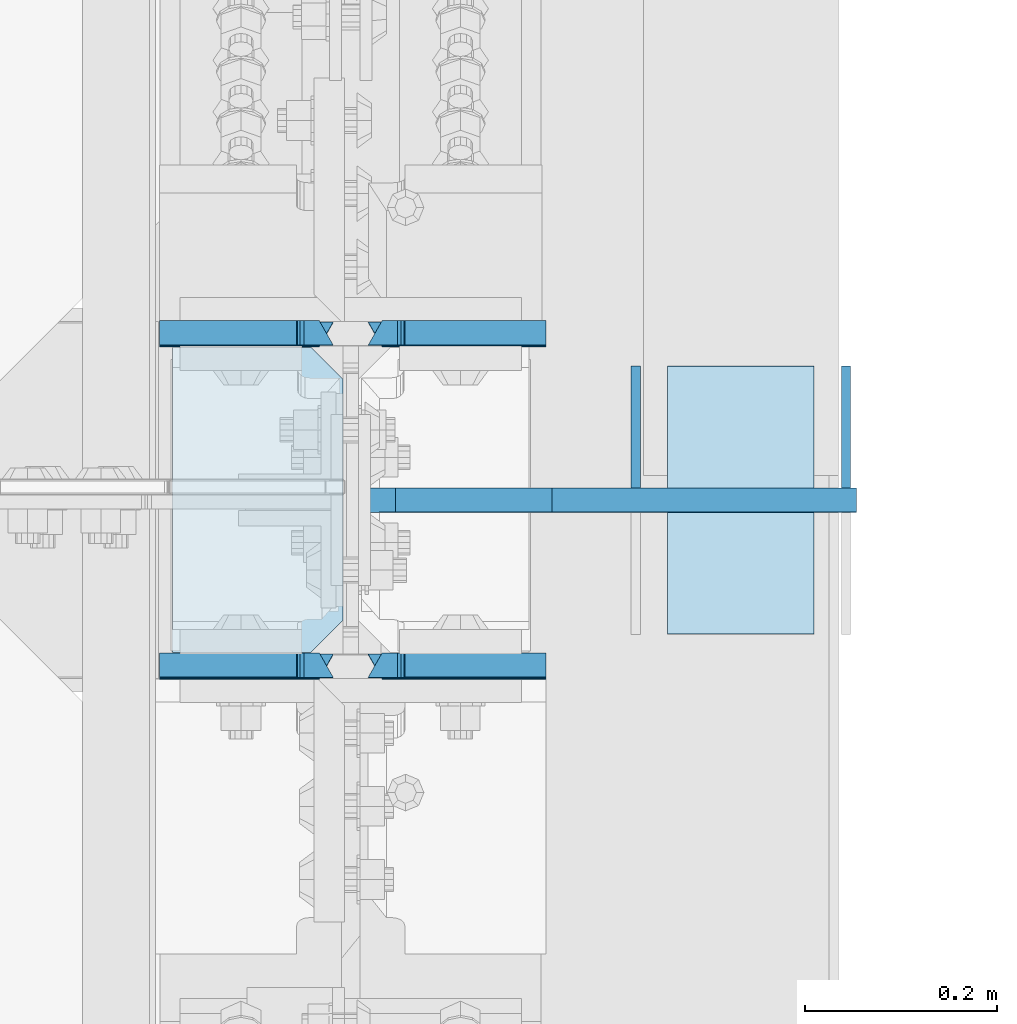
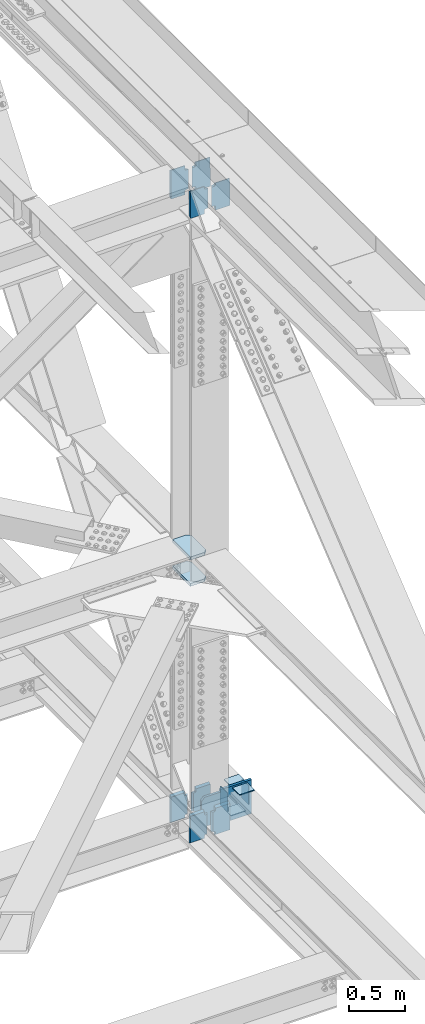
# One storey, part 3625 of 3843: 16 plates, 8 elements without a shape of their own.
"""IFC2X3 building model written with IfcOpenShell, lengths in millimetres."""

from ifc_helpers import new_model, si_unit, frame, origin_with_axes, place, context, subcontext, project, spatial, faceted_brep, material, type_object, element, aggregate, save


model = new_model("IFC2X3")

# Units and contexts
model_context = context("Model", 3, precision=1e-05, world=origin_with_axes())
body_context = subcontext(model_context, "Body", "Model", "MODEL_VIEW")
ifc_project = project(units=[si_unit("LENGTHUNIT", "METRE", prefix="MILLI"), si_unit("AREAUNIT", "SQUARE_METRE"), si_unit("VOLUMEUNIT", "CUBIC_METRE"), si_unit("MASSUNIT", "GRAM", prefix="KILO"), si_unit("TIMEUNIT", "SECOND"), si_unit("PLANEANGLEUNIT", "RADIAN"), si_unit("SOLIDANGLEUNIT", "STERADIAN"), si_unit("THERMODYNAMICTEMPERATUREUNIT", "DEGREE_CELSIUS"), si_unit("LUMINOUSINTENSITYUNIT", "LUMEN")], contexts=[model_context])

# Site, building, storey
site_placement = place(None, origin_with_axes())
site = spatial("IfcSite", under=ifc_project, at=site_placement, CompositionType="ELEMENT")
building_placement = place(site_placement, origin_with_axes())
building = spatial("IfcBuilding", under=site, at=building_placement, Name="Undefined", CompositionType="ELEMENT")
storey_placement = place(building_placement, origin_with_axes())
storey = spatial("IfcBuildingStorey", under=building, at=storey_placement, Name="Undefined", CompositionType="ELEMENT", Elevation=0.0)

# Assembly, plates
assembly_1_placement = place(storey_placement, origin_with_axes())
assembly_1 = element("IfcElementAssembly", 1, at=assembly_1_placement, inside=storey, Name="BEAM", AssemblyPlace="NOTDEFINED", PredefinedType="RIGID_FRAME")
ifc_material = material(Name="STEEL/A572-50")
plate_type_1 = type_object("IfcPlateType", PredefinedType="NOTDEFINED")
plate_1_placement = place(assembly_1_placement, frame((85852.0, 83810.7882898343, 39343.574608476), z_axis=(0.0, 0.00349392500078829, 0.999993896225416), x_axis=(-1.0, 0.0, 0.0)))
plate_1 = element("IfcPlate", 2, at=plate_1_placement, type_object=plate_type_1, material=ifc_material, Name="PLATE", context=body_context, shape_type="Brep", body=[
    faceted_brep([(0.0, 12.6999999991967, 299.81679228392), (0.0, -12.7000000008993, 314.308156892032), (146.843749999985, -12.7000000008993, 314.308156892032), (146.843749999985, 12.6999999991967, 299.81679228392), (0.0, 12.6999999999825, 14.4916120159614), (0.0, -12.6999999999971, 0.0), (146.843749999985, 12.6999999999825, 14.4916120159614), (146.843749999985, -12.7000000000844, 2.18278728425503e-11), (146.843749999985, 12.6999999999098, 38.1890602041385), (146.843749999985, -12.7000000001572, 38.1003132816259), (147.810479922569, 12.6999999998952, 43.0491693876829), (147.810479922569, -12.7000000001644, 42.9604224651703), (150.563493823051, 12.6999999998734, 47.169371005024), (150.563493823051, -12.7000000001863, 47.0806240825113), (154.683670291211, 12.6999999998734, 49.9224017096567), (154.683670291211, -12.7000000001935, 49.833654787144), (159.543749809251, 12.6999999998661, 50.8891375330786), (159.543749809251, -12.7000000001935, 50.800390610566), (170.452258242993, 12.700000000099, 50.8891375249077), (184.943749999991, -12.7000000000116, 50.8003906183731), (159.543749809251, -12.7000000008484, 263.417469232591), (154.683670291211, -12.7000000008557, 264.384205056005), (150.563493823051, -12.7000000008629, 267.137235760645), (147.810479922569, -12.7000000008702, 271.257437377986), (146.843749999985, -12.7000000008848, 276.117546561523), (184.943749999991, -12.6999999997643, 263.417469235843), (146.843749999985, 12.6999999991749, 276.206293484036), (147.810479922569, 12.6999999991895, 271.346184300499), (150.563493823051, 12.699999999204, 267.225982683158), (154.683670291211, 12.6999999992113, 264.472951978518), (159.543749809251, 12.6999999992186, 263.506216155103), (170.452258242993, 12.7000000003609, 263.506216142385)], [[[0, 1, 2, 3]], [[4, 5, 1, 0]], [[5, 4, 6, 7]], [[7, 6, 8, 9]], [[9, 8, 10, 11]], [[11, 10, 12, 13]], [[13, 12, 14, 15]], [[15, 14, 16, 17]], [[17, 16, 18, 19]], [[20, 21, 22, 23, 24, 2, 1, 5, 7, 9, 11, 13, 15, 17, 19, 25]], [[2, 24, 26, 3]], [[23, 27, 26, 24]], [[22, 28, 27, 23]], [[21, 29, 28, 22]], [[20, 30, 29, 21]], [[16, 14, 12, 10, 8, 6, 4, 0, 3, 26, 27, 28, 29, 30, 31, 18]], [[25, 19, 18, 31]], [[30, 20, 25, 31]]]),
])
plate_2_placement = place(assembly_1_placement, frame((85852.0, 84156.860333929, 39342.1240186234), z_axis=(0.0, 0.00349392500078829, 0.999993896225416), x_axis=(-1.0, 0.0, 0.0)))
plate_2 = element("IfcPlate", 3, at=plate_2_placement, type_object=plate_type_1, material=ifc_material, Name="PLATE", context=body_context, shape_type="Brep", body=[
    faceted_brep([(0.0, 12.6999999991967, 299.815314113897), (0.0, -12.7000000009139, 314.306688066332), (146.843749999985, -12.7000000009139, 314.306688066332), (146.843749999985, 12.6999999991967, 299.815314113897), (0.0, 12.699999999968, 25.3758197481584), (0.0, -12.7000000000844, 10.8843271002261), (146.843749999956, 12.699999999968, 25.3758197481584), (146.843749999956, -12.7000000000844, 10.8843271002261), (146.843749999956, 12.6999999998807, 49.0733067682668), (146.843749999956, -12.6999999951659, 48.9845598546235), (147.81047992254, 12.6999999998807, 53.9334159518039), (147.81047992254, -12.699999995617, 53.8446690381534), (150.563493823021, 12.6999999998661, 58.053617569145), (150.563493823021, -12.6999999967666, 57.9648706554945), (154.683670291182, 12.6999999998516, 60.8066482737631), (154.683670291182, -12.6999999983964, 60.7179013601199), (159.543749809221, 12.6999999998516, 61.773384097185), (159.543749809221, -12.7000000002881, 61.68463718352), (170.452258243124, 12.6999999998516, 61.773384097185), (184.943749999962, -12.7000000242551, 61.6846371834399), (159.543749809251, -12.7000000008484, 263.417469232591), (154.683670291211, -12.7000000008557, 264.384205056005), (150.563493823051, -12.7000000008629, 267.137235760645), (147.810479922569, -12.7000000008702, 271.257437377986), (146.843749999985, -12.7000000008848, 276.117546561523), (184.943749999991, -12.6999999997643, 263.417469235843), (146.843749999985, 12.6999999991749, 276.206293484036), (147.810479922569, 12.6999999991895, 271.346184300499), (150.563493823051, 12.699999999204, 267.225982683158), (154.683670291211, 12.6999999992113, 264.472951978518), (159.543749809251, 12.6999999992186, 263.506216155103), (170.452258242993, 12.7000000003609, 263.506216142385)], [[[0, 1, 2, 3]], [[4, 5, 1, 0]], [[5, 4, 6, 7]], [[7, 6, 8, 9]], [[9, 8, 10, 11]], [[11, 10, 12, 13]], [[13, 12, 14, 15]], [[15, 14, 16, 17]], [[17, 16, 18, 19]], [[20, 21, 22, 23, 24, 2, 1, 5, 7, 9, 11, 13, 15, 17, 19, 25]], [[2, 24, 26, 3]], [[23, 27, 26, 24]], [[22, 28, 27, 23]], [[21, 29, 28, 22]], [[20, 30, 29, 21]], [[16, 14, 12, 10, 8, 6, 4, 0, 3, 26, 27, 28, 29, 30, 31, 18]], [[25, 19, 18, 31]], [[30, 20, 25, 31]]]),
])

assembly_2_placement = place(storey_placement, origin_with_axes())
assembly_2 = element("IfcElementAssembly", 4, at=assembly_2_placement, inside=storey, Name="BEAM", AssemblyPlace="NOTDEFINED", PredefinedType="RIGID_FRAME")
plate_3_placement = place(assembly_2_placement, frame((85852.0, 83812.2315556504, 46115.8986620126), z_axis=(0.0, 0.00329764299921226, 0.999994562760543), x_axis=(-1.0, 0.0, 0.0)))
plate_3 = element("IfcPlate", 5, at=plate_3_placement, type_object=plate_type_1, material=ifc_material, Name="PLATE", context=body_context, shape_type="Brep", body=[
    faceted_brep([(146.843749999985, -12.7000000000771, 14.4914917543283), (0.0, -12.7000000000771, 14.4914917543283), (0.0, 12.6999999999971, 0.0), (146.843749999985, 12.7000000000262, 4.36557456851006e-11), (0.0, 12.7000000016269, 295.281578539543), (0.0, -12.6999999985273, 281.020609228879), (146.843749999985, -12.6999999985419, 280.976986643007), (146.843749999985, 12.7000000016269, 295.281578539543), (146.843749999985, -12.7000000008848, 276.117546561523), (146.843749999985, 12.6999999991749, 276.206293484036), (147.810479922569, -12.7000000008702, 271.257437377986), (147.810479922569, 12.6999999991895, 271.346184300499), (150.563493823051, -12.7000000008629, 267.137235760645), (150.563493823051, 12.699999999204, 267.225982683158), (154.683670291211, -12.7000000008557, 264.384205056005), (154.683670291211, 12.6999999992113, 264.472951978518), (159.543749809251, -12.7000000008484, 263.417469232591), (159.543749809251, 12.6999999992186, 263.506216155103), (170.452258242891, -12.699999999837, 263.417469255888), (184.943749999991, 12.7000000002081, 263.506216153903), (170.452258242891, -12.7000000000407, 50.7115631795969), (184.943749999991, 12.7000000001426, 50.8003101030481), (159.543749809265, -12.7000000000407, 50.7115631795969), (159.543749809265, 12.7000000001426, 50.8003101030481), (154.683670291226, -12.7000000000407, 49.7448273561822), (154.683670291226, 12.7000000001281, 49.8335742796335), (150.563493823065, -12.7000000000553, 46.9917966515568), (150.563493823065, 12.7000000001281, 47.0805435750153), (147.810479922584, -12.7000000000553, 42.8715950342303), (147.810479922584, 12.7000000001281, 42.9603419576888), (146.84375, -12.7000000000553, 38.0114858507077), (146.84375, 12.7000000001281, 38.1002327741662)], [[[0, 1, 2, 3]], [[4, 5, 6, 7]], [[7, 6, 8, 9]], [[10, 11, 9, 8]], [[12, 13, 11, 10]], [[14, 15, 13, 12]], [[16, 17, 15, 14]], [[17, 16, 18, 19]], [[19, 18, 20, 21]], [[22, 23, 21, 20]], [[24, 25, 23, 22]], [[26, 27, 25, 24]], [[28, 29, 27, 26]], [[30, 31, 29, 28]], [[31, 30, 0, 3]], [[4, 7, 9, 11, 13, 15, 17, 19, 21, 23, 25, 27, 29, 31, 3, 2]], [[5, 4, 2, 1]], [[30, 28, 26, 24, 22, 20, 18, 16, 14, 12, 10, 8, 6, 5, 1, 0]]]),
])
plate_4_placement = place(assembly_2_placement, frame((85852.0, 84158.303541667, 46114.4140680814), z_axis=(0.0, 0.00329764299921226, 0.999994562760543), x_axis=(-1.0, 0.0, 0.0)))
plate_4 = element("IfcPlate", 6, at=plate_4_placement, type_object=plate_type_1, material=ifc_material, Name="PLATE", context=body_context, shape_type="Brep", body=[
    faceted_brep([(146.843749999985, 12.7000000017142, 314.301781176837), (0.0, 12.7000000017142, 314.301781176837), (0.0, -12.6999999984546, 299.810289416484), (146.843749999985, -12.6999999984546, 299.810289416484), (146.843749999985, -12.7000000000771, 14.4914917543283), (0.0, -12.7000000000771, 14.4914917543283), (0.0, 12.6999999999971, 0.0), (146.843749999985, 12.7000000000262, 4.36557456851006e-11), (146.843749999985, 12.6999999999098, 38.1890602041385), (146.843749999985, -12.7000000001572, 38.1003132816259), (147.810479922569, 12.6999999998952, 43.0491693876829), (147.810479922569, -12.7000000001644, 42.9604224651703), (150.563493823051, 12.6999999998734, 47.169371005024), (150.563493823051, -12.7000000001863, 47.0806240825113), (154.683670291211, 12.6999999998734, 49.9224017096567), (154.683670291211, -12.7000000001935, 49.833654787144), (159.543749809251, 12.6999999998661, 50.8891375330786), (159.543749809251, -12.7000000001935, 50.800390610566), (184.943749999991, 12.7000000001572, 50.8891375333405), (170.452258242833, -12.7000000000262, 50.800390609882), (184.943749999991, 12.7000000002081, 263.506216153903), (170.452258242891, -12.699999999837, 263.417469255888), (159.543749809251, 12.6999999992186, 263.506216155103), (159.543749809251, -12.7000000008484, 263.417469232591), (154.683670291211, 12.6999999992113, 264.472951978518), (154.683670291211, -12.7000000008557, 264.384205056005), (150.563493823051, 12.699999999204, 267.225982683158), (150.563493823051, -12.7000000008629, 267.137235760645), (147.810479922569, 12.6999999991895, 271.346184300499), (147.810479922569, -12.7000000008702, 271.257437377986), (146.843749999985, 12.6999999991749, 276.206293484036), (146.843749999985, -12.7000000008848, 276.117546561523)], [[[0, 1, 2, 3]], [[4, 5, 6, 7]], [[8, 9, 4, 7]], [[9, 8, 10, 11]], [[11, 10, 12, 13]], [[13, 12, 14, 15]], [[15, 14, 16, 17]], [[17, 16, 18, 19]], [[20, 21, 19, 18]], [[22, 23, 21, 20]], [[23, 22, 24, 25]], [[25, 24, 26, 27]], [[27, 26, 28, 29]], [[29, 28, 30, 31]], [[31, 30, 0, 3]], [[5, 4, 9, 11, 13, 15, 17, 19, 21, 23, 25, 27, 29, 31, 3, 2]], [[6, 5, 2, 1]], [[30, 28, 26, 24, 22, 20, 18, 16, 14, 12, 10, 8, 7, 6, 1, 0]]]),
])

# Plate
plate_type_2 = type_object("IfcPlateType", PredefinedType="NOTDEFINED")
plate_5_placement = place(assembly_1_placement, frame((85630.54375, 83810.7882898345, 39343.574608476), z_axis=(0.0, 0.00349392500078829, 0.999993896225416), x_axis=(-1.0, 0.0, 0.0)))
plate_5 = element("IfcPlate", 7, at=plate_5_placement, type_object=plate_type_2, material=ifc_material, Name="PLATE", context=body_context, shape_type="Brep", body=[
    faceted_brep([(38.1000000000058, -12.6996899253718, 314.217780397244), (38.1000000000058, 12.6999999991967, 299.816792283993), (38.1000000000058, 12.6999999991749, 276.206293484051), (38.1000000000058, -12.7000000008848, 276.117546561538), (180.974999999991, -12.7000000008993, 314.308156892032), (180.974999999991, 12.6999999991967, 299.816792283993), (180.974999999991, -12.7000000000844, 2.18278728425503e-11), (180.974999999991, 12.6999999999825, 14.4916120159032), (38.1000000000058, -12.7000000000844, 2.18278728425503e-11), (38.1000000000058, 12.6999999999825, 14.4916120159032), (38.1000000000058, -12.7000000001572, 38.1003132816404), (38.1000000000058, 12.6999999999098, 38.1890602041531), (37.1332700774219, -12.7000000001644, 42.9604224651848), (37.1332700774219, 12.6999999998952, 43.0491693876975), (34.3802561769407, -12.7000000001863, 47.0806240825259), (34.3802561769407, 12.6999999998734, 47.1693710050386), (30.2600797087798, -12.7000000001935, 49.8336547871586), (30.2600797087798, 12.6999999998734, 49.9224017096712), (25.4000001907407, -12.7000000001935, 50.8003906105805), (25.4000001907407, 12.6999999998661, 50.8891375330932), (0.0, -12.7000000000262, 50.8003906045633), (14.4914917569986, 12.7000000001135, 50.8891375364256), (25.4000001907407, 12.6999999992186, 263.506216155118), (30.2600797087798, 12.6999999992113, 264.472951978532), (34.3802561769407, 12.699999999204, 267.225982683172), (37.1332700774219, 12.6999999991895, 271.346184300513), (14.4914917569986, 12.7000000003463, 263.506216154878), (37.1332700774219, -12.7000000008702, 271.257437378001), (34.3802561769407, -12.7000000008629, 267.13723576066), (30.2600797087798, -12.7000000008557, 264.38420505602), (25.4000001907407, -12.7000000008484, 263.417469232605), (0.0, -12.6999999997643, 263.417469223023)], [[[0, 1, 2, 3]], [[4, 5, 1, 0]], [[6, 7, 5, 4]], [[7, 6, 8, 9]], [[10, 11, 9, 8]], [[12, 13, 11, 10]], [[14, 15, 13, 12]], [[16, 17, 15, 14]], [[18, 19, 17, 16]], [[19, 18, 20, 21]], [[22, 23, 24, 25, 2, 1, 5, 7, 9, 11, 13, 15, 17, 19, 21, 26]], [[3, 2, 25, 27]], [[18, 16, 14, 12, 10, 8, 6, 4, 0, 3, 27, 28, 29, 30, 31, 20]], [[26, 21, 20, 31]], [[30, 22, 26, 31]], [[29, 23, 22, 30]], [[28, 24, 23, 29]], [[27, 25, 24, 28]]]),
])

plate_6_placement = place(assembly_1_placement, frame((85630.54375, 84156.860333929, 39342.1240186234), z_axis=(0.0, 0.00349392500078829, 0.999993896225416), x_axis=(-1.0, 0.0, 0.0)))
plate_6 = element("IfcPlate", 8, at=plate_6_placement, type_object=plate_type_2, material=ifc_material, Name="PLATE", context=body_context, shape_type="Brep", body=[
    faceted_brep([(38.1000000000058, -12.6996899253718, 314.217780397244), (38.1000000000058, 12.6999999991967, 299.81531411389), (38.1000000000058, 12.6999999991749, 276.206293484051), (38.1000000000058, -12.7000000008848, 276.117546561538), (180.974999999991, -12.7000000009139, 314.306688066332), (180.974999999991, 12.6999999991967, 299.81531411389), (180.974999999991, -12.7000000000844, 10.8843271002406), (180.974999999991, 12.699999999968, 25.3758197481657), (38.1000000000349, -12.7000000000844, 10.8843271002406), (38.1000000000349, 12.699999999968, 25.3758197481657), (38.1000000000349, -12.7000369811867, 48.9845597254389), (38.1000000000349, 12.6999999998807, 49.0733067683104), (37.133270077451, -12.7000348279835, 53.8446689164921), (37.133270077451, 12.6999999998807, 53.9334159518476), (34.3802561769699, -12.7000327852002, 57.9648705409709), (34.3802561769699, 12.6999999998661, 58.0536175691886), (30.2600797088089, -12.7000311637967, 60.7179012512643), (30.2600797088089, 12.6999999998516, 60.8066482738141), (25.4000001907698, -12.7000302106608, 61.6846370780186), (25.4000001907698, 12.6999999998516, 61.7733840972287), (0.0, -12.7000000002154, 61.6846371835709), (14.4914917568676, 12.6999999998516, 61.7733840972287), (25.4000001907407, 12.6999999992186, 263.506216155118), (30.2600797087798, 12.6999999992113, 264.472951978532), (34.3802561769407, 12.699999999204, 267.225982683172), (37.1332700774219, 12.6999999991895, 271.346184300513), (14.4914917569986, 12.7000000003463, 263.506216154878), (37.1332700774219, -12.7000000008702, 271.257437378001), (34.3802561769407, -12.7000000008629, 267.13723576066), (30.2600797087798, -12.7000000008557, 264.38420505602), (25.4000001907407, -12.7000000008484, 263.417469232605), (0.0, -12.6999999997643, 263.417469223023)], [[[0, 1, 2, 3]], [[4, 5, 1, 0]], [[6, 7, 5, 4]], [[7, 6, 8, 9]], [[10, 11, 9, 8]], [[12, 13, 11, 10]], [[14, 15, 13, 12]], [[16, 17, 15, 14]], [[18, 19, 17, 16]], [[19, 18, 20, 21]], [[22, 23, 24, 25, 2, 1, 5, 7, 9, 11, 13, 15, 17, 19, 21, 26]], [[3, 2, 25, 27]], [[18, 16, 14, 12, 10, 8, 6, 4, 0, 3, 27, 28, 29, 30, 31, 20]], [[26, 21, 20, 31]], [[30, 22, 26, 31]], [[29, 23, 22, 30]], [[28, 24, 23, 29]], [[27, 25, 24, 28]]]),
])

plate_7_placement = place(assembly_2_placement, frame((85630.54375, 83812.2315556503, 46115.8986620126), z_axis=(0.0, 0.00329764299921226, 0.999994562760543), x_axis=(-1.0, 0.0, 0.0)))
plate_7 = element("IfcPlate", 9, at=plate_7_placement, type_object=plate_type_2, material=ifc_material, Name="PLATE", context=body_context, shape_type="Brep", body=[
    faceted_brep([(180.974999999991, -12.7000000000844, 14.4914917571878), (38.1000000000058, -12.7000000000771, 14.4914917543283), (38.1000000000058, 12.7000000000262, 4.36557456851006e-11), (180.974999999991, 12.7000000000844, -7.27595761418343e-12), (37.1332700774074, -12.7000000000553, 42.8715950345577), (37.1332700774074, 12.7000000001281, 42.9603419580089), (38.0999999999913, 12.7000000001281, 38.1002327744864), (38.0999999999913, -12.7000000000553, 38.0114858510351), (34.3802561769262, -12.7000000000553, 46.9917966518769), (34.3802561769262, 12.7000000001281, 47.0805435753355), (30.2600797087653, -12.7000000000407, 49.7448273565024), (30.2600797087653, 12.7000000001281, 49.8335742799536), (25.4000001907261, -12.7000000000407, 50.711563179917), (25.4000001907261, 12.7000000001426, 50.8003101033755), (14.4914917571004, -12.7000000000407, 50.711563179917), (0.0, 12.7000000001426, 50.8003101033755), (14.4914917568531, -12.7000000008484, 263.417469232605), (0.0, 12.6999999992186, 263.506216155118), (25.4000001907407, -12.7000000008484, 263.417469232605), (25.4000001907407, 12.6999999992186, 263.506216155118), (30.2600797087798, -12.7000000008557, 264.38420505602), (30.2600797087798, 12.6999999992113, 264.472951978532), (34.3802561769407, -12.7000000008629, 267.13723576066), (34.3802561769407, 12.699999999204, 267.225982683172), (37.1332700774219, -12.7000000008702, 271.257437378001), (37.1332700774219, 12.6999999991895, 271.346184300513), (38.1000000000058, -12.7000000008848, 276.117546561538), (38.1000000000058, 12.6999999991749, 276.206293484051), (38.1000000000058, 12.7000000016269, 295.281578539594), (38.1000000000058, -12.6999999985419, 280.977234851191), (180.974999999991, -12.6999999985273, 281.02060922893), (180.974999999991, 12.7000000016269, 295.281578539594)], [[[0, 1, 2, 3]], [[4, 5, 6, 7]], [[8, 9, 5, 4]], [[10, 11, 9, 8]], [[12, 13, 11, 10]], [[13, 12, 14, 15]], [[16, 17, 15, 14]], [[18, 19, 17, 16]], [[20, 21, 19, 18]], [[22, 23, 21, 20]], [[24, 25, 23, 22]], [[26, 27, 25, 24]], [[28, 27, 26, 29]], [[30, 31, 28, 29]], [[31, 30, 0, 3]], [[6, 5, 9, 11, 13, 15, 17, 19, 21, 23, 25, 27, 28, 31, 3, 2]], [[7, 6, 2, 1]], [[30, 29, 26, 24, 22, 20, 18, 16, 14, 12, 10, 8, 4, 7, 1, 0]]]),
])

plate_8_placement = place(assembly_2_placement, frame((85630.54375, 84158.303541667, 46114.4140680815), z_axis=(0.0, 0.00329764299921226, 0.999994562760543), x_axis=(-1.0, 0.0, 0.0)))
plate_8 = element("IfcPlate", 10, at=plate_8_placement, type_object=plate_type_2, material=ifc_material, Name="PLATE", context=body_context, shape_type="Brep", body=[
    faceted_brep([(180.974999999991, -12.7000000000844, 14.4914917571878), (38.1000000000058, -12.7000000000771, 14.4914917543283), (38.1000000000058, 12.7000000000262, 4.36557456851006e-11), (180.974999999991, 12.7000000000844, -7.27595761418343e-12), (37.1332700774219, -12.7000000001644, 42.9604224651848), (37.1332700774219, 12.6999999998952, 43.0491693876975), (38.1000000000058, 12.6999999999098, 38.1890602041531), (38.1000000000058, -12.7000000001572, 38.1003132816404), (34.3802561769407, -12.7000000001863, 47.0806240825259), (34.3802561769407, 12.6999999998734, 47.1693710050386), (30.2600797087798, -12.7000000001935, 49.8336547871586), (30.2600797087798, 12.6999999998734, 49.9224017096712), (25.4000001907407, -12.7000000001935, 50.8003906105805), (25.4000001907407, 12.6999999998661, 50.8891375330932), (14.4914917568531, -12.7000000001935, 50.8003906105805), (0.0, 12.6999999998661, 50.8891375330932), (14.4914917568531, -12.7000000008484, 263.417469232605), (0.0, 12.6999999992186, 263.506216155118), (25.4000001907407, -12.7000000008484, 263.417469232605), (25.4000001907407, 12.6999999992186, 263.506216155118), (30.2600797087798, -12.7000000008557, 264.38420505602), (30.2600797087798, 12.6999999992113, 264.472951978532), (34.3802561769407, -12.7000000008629, 267.13723576066), (34.3802561769407, 12.699999999204, 267.225982683172), (37.1332700774219, -12.7000000008702, 271.257437378001), (37.1332700774219, 12.6999999991895, 271.346184300513), (38.1000000000058, -12.7000000008848, 276.117546561538), (38.1000000000058, 12.6999999991749, 276.206293484051), (38.1000000000058, -12.6998174858309, 299.810394790009), (38.1000000000058, 12.7000000017142, 314.301781176655), (180.974999999991, 12.7000000017142, 314.301781176655), (180.974999999991, -12.6999999984546, 299.810289416309)], [[[0, 1, 2, 3]], [[4, 5, 6, 7]], [[8, 9, 5, 4]], [[10, 11, 9, 8]], [[12, 13, 11, 10]], [[13, 12, 14, 15]], [[16, 17, 15, 14]], [[18, 19, 17, 16]], [[20, 21, 19, 18]], [[22, 23, 21, 20]], [[24, 25, 23, 22]], [[26, 27, 25, 24]], [[27, 26, 28, 29]], [[30, 29, 28, 31]], [[30, 31, 0, 3]], [[6, 5, 9, 11, 13, 15, 17, 19, 21, 23, 25, 27, 29, 30, 3, 2]], [[7, 6, 2, 1]], [[31, 28, 26, 24, 22, 20, 18, 16, 14, 12, 10, 8, 4, 7, 1, 0]]]),
])

aggregate(assembly_2, [plate_3, plate_7, plate_4, plate_8])

# Assembly, plates
assembly_3_placement = place(storey_placement, origin_with_axes())
assembly_3 = element("IfcElementAssembly", 11, at=assembly_3_placement, inside=storey, Name="COLUMN", AssemblyPlace="NOTDEFINED", PredefinedType="RIGID_FRAME")
plate_type_3 = type_object("IfcPlateType", PredefinedType="NOTDEFINED")
plate_9_placement = place(assembly_3_placement, frame((85463.0624999825, 84143.8500963299, 42127.2714828782), z_axis=(0.0, -1.0, 0.0), x_axis=(1.0, 0.0, 0.0)))
plate_9 = element("IfcPlate", 12, at=plate_9_placement, type_object=plate_type_3, material=ifc_material, Name="PLATE", context=body_context, shape_type="Brep", body=[
    faceted_brep([(0.0, -15.875, 0.0), (0.0, -15.875, 317.5), (0.0, 15.875, 317.5), (0.0, 15.875, 0.0), (144.462498511086, -15.874999999156, 317.499999999665), (144.462498511086, 15.875000000844, 317.499999999578), (177.800000033079, -15.8749999992506, 284.162498473786), (177.800000033079, 15.8750000007494, 284.162498473699), (177.800000003888, -15.8749999999054, 33.3375015259226), (177.800000003888, 15.8750000000946, 33.3375015258353), (144.462498474124, -15.875, 0.0), (144.462498474124, 15.875, 0.0)], [[[0, 1, 2, 3]], [[1, 4, 5, 2]], [[4, 6, 7, 5]], [[6, 8, 9, 7]], [[8, 10, 11, 9]], [[10, 0, 3, 11]], [[5, 7, 9, 11, 3, 2]], [[10, 8, 6, 4, 1, 0]]]),
])
plate_10_placement = place(assembly_3_placement, frame((85463.0624999815, 84143.8500863294, 42413.0215258056), z_axis=(0.0, -1.0, 0.0), x_axis=(1.0, 0.0, 0.0)))
plate_10 = element("IfcPlate", 13, at=plate_10_placement, type_object=plate_type_3, material=ifc_material, Name="PLATE", context=body_context, shape_type="Brep", body=[
    faceted_brep([(0.0, -15.875, 0.0), (0.0, -15.875, 317.5), (0.0, 15.875, 317.5), (0.0, 15.875, 0.0), (144.462498511086, -15.874999999156, 317.499999999665), (144.462498511086, 15.875000000844, 317.499999999578), (177.800000033079, -15.8749999992506, 284.162498473786), (177.800000033079, 15.8750000007494, 284.162498473699), (177.800000003888, -15.8749999999054, 33.3375015259226), (177.800000003888, 15.8750000000946, 33.3375015258353), (144.462498474124, -15.875, 0.0), (144.462498474124, 15.875, 0.0)], [[[0, 1, 2, 3]], [[1, 4, 5, 2]], [[4, 6, 7, 5]], [[6, 8, 9, 7]], [[8, 10, 11, 9]], [[10, 0, 3, 11]], [[5, 7, 9, 11, 3, 2]], [[10, 8, 6, 4, 1, 0]]]),
])
aggregate(assembly_3, [plate_9, plate_10])

# Plate
plate_type_4 = type_object("IfcPlateType", PredefinedType="NOTDEFINED")
plate_11_placement = place(assembly_1_placement, frame((86175.8500000045, 83984.5277251634, 39315.8690965061), z_axis=(0.0, 0.00146611400037363, 0.999998925254291), x_axis=(-1.0, 0.0, 0.0)))
plate_11 = element("IfcPlate", 14, at=plate_11_placement, type_object=plate_type_4, material=ifc_material, Name="STIFFENER", context=body_context, shape_type="Brep", body=[
    faceted_brep([(0.0, -12.6999999999971, 0.0), (1.43627403303981e-08, -12.7000000003172, 368.282421855467), (1.43627403303981e-08, 12.6999999996769, 368.282421855489), (0.0, 12.6999999999971, 0.0), (317.500000026223, -12.7000000003172, 368.282421839234), (317.500000026223, 12.6999999996769, 368.282421839256), (317.500000024767, -12.7000000002881, 342.88242181766), (317.500000024767, 12.6999999996915, 342.882421817681), (480.218749970372, -12.7000000002881, 342.882421787188), (480.218749970372, 12.6999999996915, 342.88242178721), (511.968749969019, -12.700000000259, 311.132421781258), (511.968749969019, 12.6999999997206, 311.132421781287), (511.968749958221, -12.7000000000553, 57.1500000187953), (511.968749958221, 12.6999999999389, 57.1500000188171), (480.218749956868, -12.7000000000116, 25.4000000166852), (480.218749956868, 12.6999999999825, 25.4000000167216), (317.500000000146, -12.7000000000116, 25.4000000058295), (317.500000000146, 12.699999999968, 25.4000000058659), (317.50000000211, -12.6999999999971, -8.14907252788544e-10), (317.50000000211, 12.6999999999971, -7.93079379945993e-10)], [[[0, 1, 2, 3]], [[1, 4, 5, 2]], [[4, 6, 7, 5]], [[6, 8, 9, 7]], [[8, 10, 11, 9]], [[10, 12, 13, 11]], [[12, 14, 15, 13]], [[14, 16, 17, 15]], [[16, 18, 19, 17]], [[18, 0, 3, 19]], [[5, 7, 9, 11, 13, 15, 17, 19, 3, 2]], [[18, 16, 14, 12, 10, 8, 6, 4, 1, 0]]]),
])

aggregate(assembly_1, [plate_11, plate_1, plate_5, plate_2, plate_6])

# Assembly, plate
assembly_4_placement = place(storey_placement, origin_with_axes())
assembly_4 = element("IfcElementAssembly", 15, at=assembly_4_placement, inside=storey, Name="PLATE", AssemblyPlace="NOTDEFINED", PredefinedType="RIGID_FRAME")
plate_type_5 = type_object("IfcPlateType", PredefinedType="NOTDEFINED")
plate_12_placement = place(assembly_4_placement, frame((86131.3999975899, 83972.3343322953, 39660.2927265175), z_axis=(0.0, -0.99999892529974, 0.00146608300043589), x_axis=(-1.0, 0.0, 0.0)))
plate_12 = element("IfcPlate", 16, at=plate_12_placement, type_object=plate_type_5, material=ifc_material, Name="PLATE", context=body_context, shape_type="Brep", body=[
    faceted_brep([(0.0, -4.76249999999709, 0.0), (-5.82076609134674e-11, -4.76249999972788, 126.999999995154), (-5.82076609134674e-11, 4.76250000024447, 126.999999995183), (0.0, 4.76249999999709, 0.0), (152.399999999951, -4.76249999972788, 126.999999995154), (152.399999999951, 4.76250000024447, 126.999999995183), (152.399993896484, -4.76249999999709, 0.0), (152.399993896484, 4.76249999999709, 0.0)], [[[0, 1, 2, 3]], [[1, 4, 5, 2]], [[4, 6, 7, 5]], [[6, 0, 3, 7]], [[5, 7, 3, 2]], [[6, 4, 1, 0]]]),
])
aggregate(assembly_4, [plate_12])

assembly_5_placement = place(storey_placement, origin_with_axes())
assembly_5 = element("IfcElementAssembly", 17, at=assembly_5_placement, inside=storey, Name="PLATE", AssemblyPlace="NOTDEFINED", PredefinedType="RIGID_FRAME")
plate_13_placement = place(assembly_5_placement, frame((85945.6625, 83997.5745712487, 39603.2340154098), z_axis=(0.0, 0.999999731313681, -0.000733057000201368), x_axis=(0.0, -0.000733042000252022, -0.999999731324677)))
plate_13 = element("IfcPlate", 18, at=plate_13_placement, type_object=plate_type_5, material=ifc_material, Name="PLATE", context=body_context, shape_type="Brep", body=[
    faceted_brep([(0.0, -4.76249999999709, 0.0), (0.0930982761929044, -4.76249999999709, 126.999965875119), (0.0930982761929044, 4.76249999999709, 126.999965875119), (0.0, 4.76249999999709, 0.0), (203.293043677208, -4.76249999999709, 126.999965876414), (203.293043677208, 4.76249999999709, 126.999965876414), (203.199945405628, -4.76249999999709, 1.00408215075731e-09), (203.199945405628, 4.76249999999709, 1.00408215075731e-09)], [[[0, 1, 2, 3]], [[1, 4, 5, 2]], [[4, 6, 7, 5]], [[6, 0, 3, 7]], [[5, 7, 3, 2]], [[6, 4, 1, 0]]]),
])
aggregate(assembly_5, [plate_13])

assembly_6_placement = place(storey_placement, origin_with_axes())
assembly_6 = element("IfcElementAssembly", 19, at=assembly_6_placement, inside=storey, Name="PLATE", AssemblyPlace="NOTDEFINED", PredefinedType="RIGID_FRAME")
plate_14_placement = place(assembly_6_placement, frame((86164.7375000001, 83997.574571249, 39603.2340154098), z_axis=(0.0, 0.999999731313681, -0.000733057000201368), x_axis=(0.0, -0.000733042000252022, -0.999999731324677)))
plate_14 = element("IfcPlate", 20, at=plate_14_placement, type_object=plate_type_5, material=ifc_material, Name="PLATE", context=body_context, shape_type="Brep", body=[
    faceted_brep([(0.0, -4.76249999999709, 0.0), (0.0930982761929044, -4.76249999999709, 126.999965875119), (0.0930982761929044, 4.76249999999709, 126.999965875119), (0.0, 4.76249999999709, 0.0), (203.293043677208, -4.76249999999709, 126.999965876414), (203.293043677208, 4.76249999999709, 126.999965876414), (203.199945405628, -4.76249999999709, 1.00408215075731e-09), (203.199945405628, 4.76249999999709, 1.00408215075731e-09)], [[[0, 1, 2, 3]], [[1, 4, 5, 2]], [[4, 6, 7, 5]], [[6, 0, 3, 7]], [[5, 7, 3, 2]], [[6, 4, 1, 0]]]),
])
aggregate(assembly_6, [plate_14])

assembly_7_placement = place(storey_placement, origin_with_axes())
assembly_7 = element("IfcElementAssembly", 21, at=assembly_7_placement, inside=storey, Name="PLATE", AssemblyPlace="NOTDEFINED", PredefinedType="RIGID_FRAME")
plate_15_placement = place(assembly_7_placement, frame((86131.4000000045, 83997.2673710888, 39342.8839168843), z_axis=(0.0, 0.999998925254291, -0.00146611400037364), x_axis=(-1.0, 0.0, 0.0)))
plate_15 = element("IfcPlate", 22, at=plate_15_placement, type_object=plate_type_5, material=ifc_material, Name="PLATE", context=body_context, shape_type="Brep", body=[
    faceted_brep([(0.0, -4.76249999999709, 0.0), (-5.82076609134674e-11, -4.76249999972788, 126.999999995154), (-5.82076609134674e-11, 4.76250000024447, 126.999999995183), (0.0, 4.76249999999709, 0.0), (152.399999999951, -4.76249999972788, 126.999999995154), (152.399999999951, 4.76250000024447, 126.999999995183), (152.399993896484, -4.76249999999709, 0.0), (152.399993896484, 4.76249999999709, 0.0)], [[[0, 1, 2, 3]], [[1, 4, 5, 2]], [[4, 6, 7, 5]], [[6, 0, 3, 7]], [[5, 7, 3, 2]], [[6, 4, 1, 0]]]),
])
aggregate(assembly_7, [plate_15])

assembly_8_placement = place(storey_placement, origin_with_axes())
assembly_8 = element("IfcElementAssembly", 23, at=assembly_8_placement, inside=storey, Name="PLATE", AssemblyPlace="NOTDEFINED", PredefinedType="RIGID_FRAME")
plate_16_placement = place(assembly_8_placement, frame((86131.3999975899, 83997.7328585906, 39660.3838993622), z_axis=(0.0, 0.999998925254291, -0.00146611400037364), x_axis=(-1.0, 0.0, 0.0)))
plate_16 = element("IfcPlate", 24, at=plate_16_placement, type_object=plate_type_5, material=ifc_material, Name="PLATE", context=body_context, shape_type="Brep", body=[
    faceted_brep([(0.0, -4.76249999999709, 0.0), (-5.82076609134674e-11, -4.76249999972788, 126.999999995154), (-5.82076609134674e-11, 4.76250000024447, 126.999999995183), (0.0, 4.76249999999709, 0.0), (152.399999999951, -4.76249999972788, 126.999999995154), (152.399999999951, 4.76250000024447, 126.999999995183), (152.399993896484, -4.76249999999709, 0.0), (152.399993896484, 4.76249999999709, 0.0)], [[[0, 1, 2, 3]], [[1, 4, 5, 2]], [[4, 6, 7, 5]], [[6, 0, 3, 7]], [[5, 7, 3, 2]], [[6, 4, 1, 0]]]),
])
aggregate(assembly_8, [plate_16])

save(model, "model.ifc")
